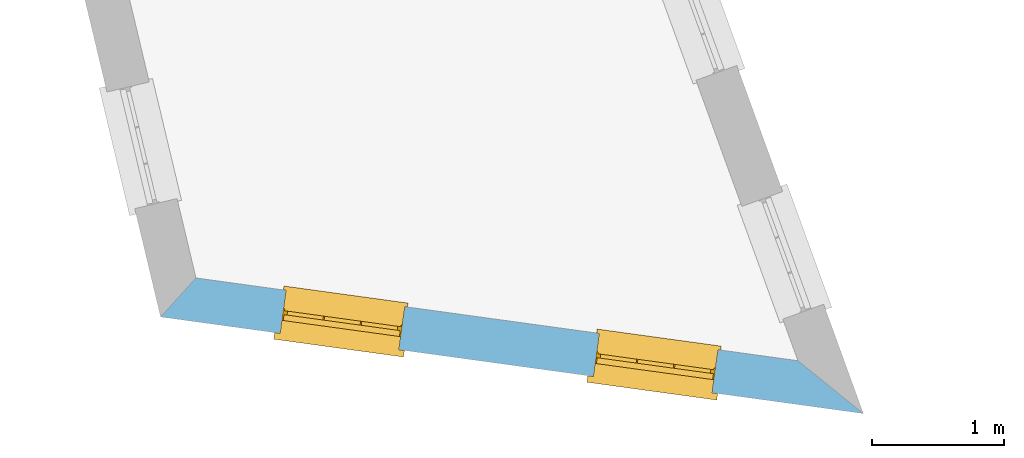
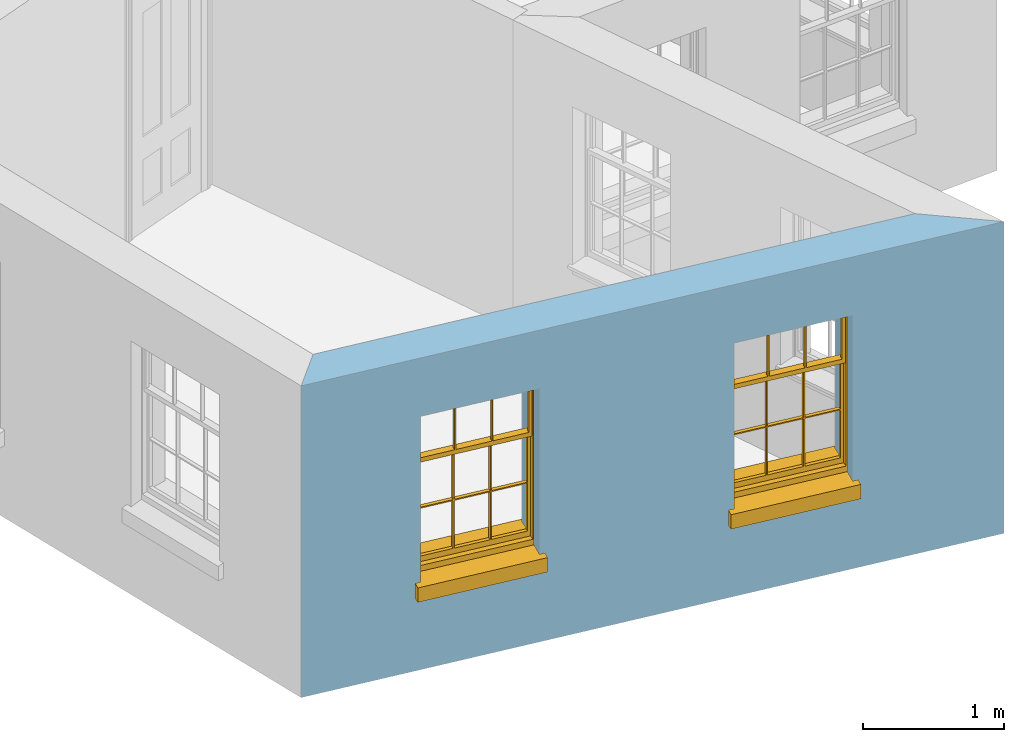
# One storey, part 3 of 12: 2 windows, 2 openings, plus 1 element that does not belong to this part.
"""IFC2X3 building model written with IfcOpenShell, lengths in metres."""

import ifcopenshell
import ifcopenshell.guid

model = None  # the IFC model being written
_history = None  # IfcOwnerHistory: only IFC2X3 demands one
_inside = {}  # id of a spatial element -> (the spatial element, [elements in it])
_under = {}  # id of a project, library or spatial element -> (it, [spatial elements below it])
_declared = {}  # id of a project -> (the project, [libraries it declares])
_typed = {}  # id of a type object -> (the type object, [elements of that type])
_made_of = {}  # id of a material, layer set ... -> (it, [elements and type objects made of it])


def new_model(schema):
    """Start an empty IFC model of exactly this schema.

    Asked for "IFC4X3", IfcOpenShell would pick the latest addendum, in which some entities
    have other attributes; the version numbers below select the first issue.
    IFC2X3 requires an IfcOwnerHistory on every rooted entity: one is made here for all.
    """
    global model, _history
    if schema == "IFC4X3":
        model = ifcopenshell.file(schema_version=(4, 3, 0, 0))
    else:
        model = ifcopenshell.file(schema=schema)
    _inside.clear()
    _under.clear()
    _declared.clear()
    _typed.clear()
    _made_of.clear()
    _history = None
    if model.schema == "IFC2X3":
        org = make("IfcOrganization", Name="unknown")
        user = make(
            "IfcPersonAndOrganization",
            ThePerson=make("IfcPerson", FamilyName="unknown"),
            TheOrganization=org,
        )
        app = make(
            "IfcApplication",
            ApplicationDeveloper=org,
            Version="unknown",
            ApplicationFullName="unknown",
            ApplicationIdentifier="unknown",
        )
        _history = make(
            "IfcOwnerHistory",
            OwningUser=user,
            OwningApplication=app,
            ChangeAction="ADDED",
            CreationDate=0,
        )
    return model


def make(cls, **values):
    """One entity of the class cls with the attributes given. An attribute that is None is left unset."""
    return model.create_entity(
        cls, **{name: value for name, value in values.items() if value is not None}
    )


def rooted(cls, **values):
    """An entity with a GlobalId (a new one), such as an element, a storey or a relation."""
    return make(cls, GlobalId=ifcopenshell.guid.new(), OwnerHistory=_history, **values)


def si_unit(unit_type, name, prefix=None):
    """IfcSIUnit, for example si_unit("LENGTHUNIT", "METRE", prefix="MILLI")."""
    return make("IfcSIUnit", UnitType=unit_type, Prefix=prefix, Name=name)


def assignment(units):
    """IfcUnitAssignment: the units of a project."""
    return None if units is None else make("IfcUnitAssignment", Units=units)


def point(xyz):
    """IfcCartesianPoint."""
    return None if xyz is None else make("IfcCartesianPoint", Coordinates=xyz)


def direction(xyz):
    """IfcDirection."""
    return None if xyz is None else make("IfcDirection", DirectionRatios=xyz)


def frame(location, z_axis=None, x_axis=None):
    """IfcAxis2Placement3D, a coordinate frame: its origin and axes. An axis left out is left unset."""
    return make(
        "IfcAxis2Placement3D",
        Location=point(location),
        Axis=direction(z_axis),
        RefDirection=direction(x_axis),
    )


def origin():
    """The frame at (0, 0, 0) with its axes left unset."""
    return frame((0.0, 0.0, 0.0))


def place(relative_to, where):
    """IfcLocalPlacement: puts the frame where relative to a parent placement (None: the world)."""
    return make(
        "IfcLocalPlacement", PlacementRelTo=relative_to, RelativePlacement=where
    )


def context(
    kind, dimensions, precision=None, world=None, true_north=None, identifier=None
):
    """IfcGeometricRepresentationContext, for example the 3D "Model" context."""
    return make(
        "IfcGeometricRepresentationContext",
        ContextIdentifier=identifier,
        ContextType=kind,
        CoordinateSpaceDimension=dimensions,
        Precision=precision,
        WorldCoordinateSystem=world,
        TrueNorth=true_north,
    )


def subcontext(parent, identifier, kind, view, scale=None):
    """IfcGeometricRepresentationSubContext, for example "Body" below "Model"."""
    return make(
        "IfcGeometricRepresentationSubContext",
        ContextIdentifier=identifier,
        ContextType=kind,
        ParentContext=parent,
        TargetScale=scale,
        TargetView=view,
    )


def project(units=None, contexts=None):
    """IfcProject with its units and contexts."""
    return rooted(
        "IfcProject",
        Name="project",
        RepresentationContexts=contexts,
        UnitsInContext=assignment(units),
    )


def spatial(cls, under=None, at=None, **own):
    """A site, building, storey or space (cls), placed at a placement, below another one or the project."""
    s = rooted(cls, ObjectPlacement=at, **own)
    if under is not None:
        _under.setdefault(under.id(), (under, []))[1].append(s)
    return s


def polyline(points):
    """IfcPolyline through the points."""
    return make("IfcPolyline", Points=[point(p) for p in points])


def outline(outer, holes=None, kind="AREA"):
    """IfcArbitraryClosedProfileDef: a profile drawn as a closed curve; with holes, ...WithVoids."""
    if holes is None:
        return make("IfcArbitraryClosedProfileDef", ProfileType=kind, OuterCurve=outer)
    return make(
        "IfcArbitraryProfileDefWithVoids",
        ProfileType=kind,
        OuterCurve=outer,
        InnerCurves=holes,
    )


def extrude(swept, where, along, depth):
    """IfcExtrudedAreaSolid: the profile swept, set in the frame where, extruded along a direction by depth."""
    return make(
        "IfcExtrudedAreaSolid",
        SweptArea=swept,
        Position=where,
        ExtrudedDirection=direction(along),
        Depth=depth,
    )


def faces_of(points, faces, orient=None, outer=None):
    """IfcFace entities. A face is a list of loops; a loop is a list of indices into points, from 0.

    orient and outer hold one flag for each loop. By default every Orientation is true, the
    first loop of a face is its IfcFaceOuterBound and the others are IfcFaceBound.
    """
    made = []
    for i, loops in enumerate(faces):
        bounds = []
        for j, loop in enumerate(loops):
            is_outer = j == 0 if outer is None else outer[i][j]
            bounds.append(
                make(
                    "IfcFaceOuterBound" if is_outer else "IfcFaceBound",
                    Bound=make("IfcPolyLoop", Polygon=[points[k] for k in loop]),
                    Orientation=True if orient is None else orient[i][j],
                )
            )
        made.append(make("IfcFace", Bounds=bounds))
    return made


def faceted_brep(points, faces, orient=None, outer=None, voids=None):
    """IfcFacetedBrep: a solid bounded by flat faces; with voids (closed shells), ...WithVoids."""
    shared = [point(p) for p in points]
    hull = make("IfcClosedShell", CfsFaces=faces_of(shared, faces, orient, outer))
    if voids is None:
        return make("IfcFacetedBrep", Outer=hull)
    return make(
        "IfcFacetedBrepWithVoids",
        Outer=hull,
        Voids=[
            make(cls, CfsFaces=faces_of(shared, fs, o, b)) for cls, fs, o, b in voids
        ],
    )


def shape(context_of_items, identifier, shape_type, items):
    """IfcShapeRepresentation: the items that make up one representation, for example the "Body"."""
    return make(
        "IfcShapeRepresentation",
        ContextOfItems=context_of_items,
        RepresentationIdentifier=identifier,
        RepresentationType=shape_type,
        Items=items,
    )


def material(Name=None, Category=None):
    """IfcMaterial."""
    return make("IfcMaterial", Name=Name, Category=Category)


def layer(
    of_material, thickness, ventilated=None, Name=None, Category=None, Priority=None
):
    """IfcMaterialLayer: one layer of a wall or slab, of a material (None: an air gap)."""
    return make(
        "IfcMaterialLayer",
        Material=of_material,
        LayerThickness=thickness,
        IsVentilated=ventilated,
        Name=Name,
        Category=Category,
        Priority=Priority,
    )


def layer_set(layers, Name=None):
    """IfcMaterialLayerSet."""
    return make("IfcMaterialLayerSet", MaterialLayers=layers, LayerSetName=Name)


def layer_usage(for_layer_set, set_direction, sense, offset, extent=None):
    """IfcMaterialLayerSetUsage: how a layer set lies in its element."""
    return make(
        "IfcMaterialLayerSetUsage",
        ForLayerSet=for_layer_set,
        LayerSetDirection=set_direction,
        DirectionSense=sense,
        OffsetFromReferenceLine=offset,
        ReferenceExtent=extent,
    )


def made_of(thing, what):
    """Note that an element or type object is made of a material, layer set ...; save() writes the relation."""
    if what is not None:
        _made_of.setdefault(what.id(), (what, []))[1].append(thing)
    return thing


def element(
    cls,
    number,
    at=None,
    inside=None,
    cuts=None,
    type_object=None,
    material=None,
    context=None,
    identifier="Body",
    shape_type=None,
    held_by="IfcProductDefinitionShape",
    body=None,
    shapes=None,
    **own,
):
    """One element of the class cls, such as IfcWall. Its Tag is "e" and its number.

    at: its placement. inside: the storey or other place that contains it. cuts: it is an
    opening in that element (IfcRelVoidsElement). A single representation is given by context,
    identifier, shape_type and body (its items); several are given by shapes. held_by: the class
    of the entity that holds the representations. save() writes the other relations.
    """
    e = rooted(cls, Tag="e%d" % number, ObjectPlacement=at, **own)
    if body is not None:
        shapes = [shape(context, identifier, shape_type, body)]
    if shapes is not None:
        e.Representation = make(held_by, Representations=shapes)
    if inside is not None:
        _inside.setdefault(inside.id(), (inside, []))[1].append(e)
    if cuts is not None:
        rooted(
            "IfcRelVoidsElement", RelatingBuildingElement=cuts, RelatedOpeningElement=e
        )
    if type_object is not None:
        _typed.setdefault(type_object.id(), (type_object, []))[1].append(e)
    return made_of(e, material)


def fill(opening, filler):
    """IfcRelFillsElement: the door or window that sits in an opening."""
    return rooted(
        "IfcRelFillsElement",
        RelatingOpeningElement=opening,
        RelatedBuildingElement=filler,
    )


def aggregate(whole, parts):
    """IfcRelAggregates: a whole, such as a stair, and the parts it consists of."""
    return rooted("IfcRelAggregates", RelatingObject=whole, RelatedObjects=parts)


def save(model, path):
    """Write the relations noted so far, then the file.

    IfcRelAggregates (storeys below a building ...), IfcRelContainedInSpatialStructure (elements
    in a storey), IfcRelDefinesByType, IfcRelAssociatesMaterial and IfcRelDeclares: one each for
    every whole, place, type object, material and project.
    """
    for whole, parts in _under.values():
        aggregate(whole, parts)
    for where, things in _inside.values():
        rooted(
            "IfcRelContainedInSpatialStructure",
            RelatedElements=things,
            RelatingStructure=where,
        )
    for kind, things in _typed.values():
        rooted("IfcRelDefinesByType", RelatedObjects=things, RelatingType=kind)
    for what, things in _made_of.values():
        rooted("IfcRelAssociatesMaterial", RelatedObjects=things, RelatingMaterial=what)
    for by, libraries in _declared.values():
        rooted("IfcRelDeclares", RelatingContext=by, RelatedDefinitions=libraries)
    model.write(path)


model = new_model("IFC2X3")

# Units and contexts
model_context = context("Model", 3, world=origin())
body_context = subcontext(model_context, "Body", "Model", "MODEL_VIEW")
ifc_project = project(units=[si_unit("PLANEANGLEUNIT", "RADIAN"), si_unit("MASSUNIT", "GRAM", prefix="KILO"), si_unit("FORCEUNIT", "NEWTON", prefix="KILO"), si_unit("LENGTHUNIT", "METRE")], contexts=[model_context])

# Site, building, storey
site_placement = place(None, origin())
site = spatial("IfcSite", under=ifc_project, at=site_placement, CompositionType="ELEMENT")
building_placement = place(None, origin())
building = spatial("IfcBuilding", under=site, at=building_placement, Name="Building plot-12", CompositionType="ELEMENT")
storey_placement = place(None, frame((0.0, 0.0, 6.45)))
storey = spatial("IfcBuildingStorey", under=building, at=storey_placement, Name="Floor 1", CompositionType="ELEMENT", Elevation=6.45)

# Wall, openings, windows
ifc_material = material(Name="Masonry")
ifc_layer = layer(ifc_material, 0.33, ventilated=False)
ifc_layer_set = layer_set([ifc_layer], Name="My Wall")
ifc_layer_usage = layer_usage(ifc_layer_set, "AXIS2", "NEGATIVE", 0.08)
wall_placement = place(storey_placement, origin())
wall = element("IfcWallStandardCase", 1, at=wall_placement, inside=storey, material=ifc_layer_usage, Name="exterior", context=body_context, shape_type="SweptSolid", body=[
    extrude(outline(polyline([(55.7885191142734, 31.8858296755126), (55.519891283054, 31.5896553921575), (60.8543376208598, 30.856304618938), (60.357257872223, 31.2577442307242), (55.7885191142734, 31.8858296755126)])), origin(), (0.0, 0.0, 1.0), 2.7),
])
opening_1_placement = place(storey_placement, frame((0.0, 0.0, 0.75)))
opening_1 = element("IfcOpeningElement", 2, at=opening_1_placement, cuts=wall, Name="Opening", ObjectType="Opening", context=body_context, shape_type="SweptSolid", body=[
    extrude(outline(polyline([(56.4271796007389, 31.4649263111671), (57.3287004372119, 31.3409901122377), (57.3736443335269, 31.6679152507388), (56.472123497054, 31.7918514496683), (56.4271796007389, 31.4649263111671)])), origin(), (0.0, 0.0, 1.0), 1.445),
])
opening_2_placement = place(storey_placement, frame((0.0, 0.0, 0.75)))
opening_2 = element("IfcOpeningElement", 3, at=opening_2_placement, cuts=wall, Name="Opening", ObjectType="Opening", context=body_context, shape_type="SweptSolid", body=[
    extrude(outline(polyline([(58.8043620196962, 31.1381241550237), (59.7058828561692, 31.0141879560943), (59.7508267524843, 31.3411130945954), (58.8493059160113, 31.4650492935249), (58.8043620196962, 31.1381241550237)])), origin(), (0.0, 0.0, 1.0), 1.445),
])
window_1_placement = place(storey_placement, frame((56.4612280070382, 31.7125968706377, 0.75), z_axis=(0.0, 0.0, 1.0), x_axis=(0.901520836472962, -0.123936198929485, 0.0)))
window_1 = element("IfcWindow", 4, at=window_1_placement, inside=storey, Name="living outside window", OverallHeight=1.445, OverallWidth=0.91, context=body_context, shape_type="Brep", held_by="IfcProductRepresentation", body=[
    faceted_brep([(0.876875, -0.105, 0.999097), (0.876875, -0.105, 1.411875), (0.9, -0.105, 1.435), (0.033125, -0.105, 1.411875), (0.033125, -0.105, 0.999097), (0.01, -0.105, 1.435), (0.033125, -0.135, 1.411875), (0.01, -0.135, 1.435), (0.033125, -0.135, 0.999097), (0.876875, -0.135, 1.411875), (0.876875, -0.135, 0.999097), (0.9, -0.135, 1.435), (0.033125, -0.105, 0.960972), (0.01, -0.105, 0.960972), (0.033125, -0.105, 0.548195), (0.876875, -0.105, 0.960972), (0.876875, -0.105, 0.548195), (0.9, -0.105, 0.960972), (0.876875, -0.105, 0.538195), (0.876875, -0.105, 0.125417), (0.9, -0.105, 0.077167), (0.033125, -0.105, 0.125417), (0.033125, -0.105, 0.538195), (0.01, -0.105, 0.077167), (0.9, -0.135, 0.960972), (0.01, -0.135, 0.960972), (-0.0425, -0.25, 0.01), (-0.0425, -0.3, 0.001667), (0.0, -0.25, 0.01), (0.9525, -0.25, 0.01), (0.91, -0.25, 0.01), (0.9525, -0.3, 0.001667), (-0.02, 0.08, 0.077167), (0.0, 0.08, 0.077167), (-0.02, 0.11, 0.077167), (0.0, -0.06, 0.077167), (0.01, -0.06, 0.077167), (0.91, -0.06, 0.077167), (0.91, 0.08, 0.077167), (0.9, -0.06, 0.077167), (0.93, 0.08, 0.077167), (0.93, 0.11, 0.077167), (0.01, -0.105, 0.999097), (0.01, -0.075, 0.999097), (0.9, -0.105, 0.999097), (0.9, -0.075, 0.999097), (0.876875, -0.075, 0.125417), (0.876875, -0.075, 0.538195), (0.9, -0.075, 0.077167), (0.876875, -0.075, 0.548195), (0.876875, -0.075, 0.960972), (0.033125, -0.075, 0.125417), (0.01, -0.075, 0.077167), (0.033125, -0.075, 0.538195), (0.033125, -0.075, 0.960972), (0.033125, -0.075, 0.548195), (-0.02, 0.08, 0.052167), (-0.02, 0.11, 0.052167), (0.93, 0.11, 0.052167), (0.93, 0.08, 0.052167), (0.91, 0.08, 0.052167), (0.0, 0.08, 0.052167), (0.91, -0.15, 0.026667), (0.0, -0.15, 0.026667), (-0.0425, -0.3, -0.123333), (0.9525, -0.3, -0.123333), (-0.0425, -0.25, -0.123333), (0.9525, -0.25, -0.123333), (0.01, -0.06, 1.435), (0.9, -0.06, 1.435), (0.0, -0.06, 1.445), (0.91, -0.06, 1.445), (0.01, -0.15, 0.077167), (0.9, -0.15, 0.077167), (0.592292, -0.105, 0.125417), (0.592292, -0.075, 0.125417), (0.317708, -0.075, 0.125417), (0.317708, -0.105, 0.125417), (0.592292, -0.105, 0.548195), (0.317708, -0.105, 0.548195), (0.317708, -0.105, 0.538195), (0.592292, -0.105, 0.538195), (0.592292, -0.075, 0.548195), (0.317708, -0.075, 0.548195), (0.602292, -0.075, 0.548195), (0.602292, -0.105, 0.548195), (0.317708, -0.075, 0.538195), (0.307708, -0.075, 0.125417), (0.307708, -0.075, 0.538195), (0.602292, -0.075, 0.538195), (0.602292, -0.075, 0.125417), (0.592292, -0.075, 0.538195), (0.307708, -0.075, 0.548195), (0.317708, -0.075, 0.960972), (0.307708, -0.075, 0.960972), (0.602292, -0.075, 0.960972), (0.592292, -0.075, 0.960972), (0.307708, -0.105, 0.538195), (0.307708, -0.105, 0.125417), (0.307708, -0.105, 0.548195), (0.307708, -0.105, 0.960972), (0.592292, -0.105, 0.960972), (0.317708, -0.105, 0.960972), (0.602292, -0.105, 0.960972), (0.602292, -0.105, 0.538195), (0.602292, -0.105, 0.125417), (0.317708, -0.135, 1.411875), (0.307708, -0.135, 1.411875), (0.307708, -0.135, 0.999097), (0.317708, -0.135, 0.999097), (0.602292, -0.135, 1.411875), (0.592292, -0.135, 1.411875), (0.592292, -0.135, 0.999097), (0.602292, -0.135, 0.999097), (0.317708, -0.105, 0.999097), (0.307708, -0.105, 0.999097), (0.307708, -0.105, 1.411875), (0.317708, -0.105, 1.411875), (0.602292, -0.105, 0.999097), (0.592292, -0.105, 0.999097), (0.592292, -0.105, 1.411875), (0.602292, -0.105, 1.411875), (0.91, -0.15, 1.445), (0.9, -0.15, 1.435), (0.01, -0.15, 1.435), (0.0, -0.15, 1.445), (0.91, -0.25, 0.0), (0.0, -0.25, 0.0), (0.91, 0.08, 0.0), (0.0, 0.08, 0.0)], [[[0, 1, 2]], [[3, 4, 5]], [[6, 7, 8]], [[9, 10, 11]], [[12, 13, 14]], [[15, 16, 17]], [[18, 19, 20]], [[21, 22, 23]], [[24, 15, 17]], [[13, 12, 25]], [[26, 27, 28]], [[29, 30, 31]], [[32, 33, 34]], [[35, 36, 33]], [[37, 38, 39]], [[40, 41, 38]], [[42, 4, 43]], [[44, 45, 0]], [[46, 47, 48]], [[49, 50, 45]], [[51, 52, 53]], [[54, 55, 43]], [[38, 33, 36, 39]], [[41, 34, 33, 38]], [[56, 32, 34, 57]], [[57, 34, 41, 58]], [[58, 41, 40, 59]], [[57, 58, 60, 61]], [[52, 48, 39, 36]], [[62, 63, 28, 30]], [[27, 31, 30, 28]], [[27, 64, 65, 31]], [[66, 67, 65, 64]], [[2, 5, 68, 69]], [[68, 70, 71, 69]], [[20, 23, 72, 73]], [[73, 72, 63, 62]], [[74, 75, 76, 77]], [[78, 79, 80, 81]], [[78, 82, 83, 79]], [[16, 49, 84, 85]], [[86, 76, 87, 88]], [[89, 90, 75, 91]], [[92, 88, 53, 55]], [[82, 91, 86, 83]], [[93, 83, 92, 94]], [[95, 84, 82, 96]], [[89, 84, 49, 47]], [[97, 88, 87, 98]], [[22, 53, 88, 97]], [[81, 91, 75, 74]], [[80, 86, 91, 81]], [[77, 76, 86, 80]], [[99, 92, 55, 14]], [[100, 94, 92, 99]], [[101, 96, 82, 78]], [[79, 83, 93, 102]], [[85, 84, 95, 103]], [[104, 89, 47, 18]], [[105, 90, 89, 104]], [[104, 18, 16, 85]], [[80, 97, 98, 77]], [[104, 81, 74, 105]], [[103, 101, 78, 85]], [[99, 14, 22, 97]], [[102, 100, 99, 79]], [[106, 107, 108, 109]], [[110, 111, 112, 113]], [[114, 115, 116, 117]], [[118, 119, 120, 121]], [[107, 116, 115, 108]], [[111, 120, 119, 112]], [[109, 114, 117, 106]], [[113, 118, 121, 110]], [[85, 78, 81, 104]], [[84, 89, 91, 82]], [[83, 86, 88, 92]], [[79, 99, 97, 80]], [[109, 112, 119, 114]], [[102, 93, 96, 101]], [[106, 117, 120, 111]], [[98, 87, 51, 21]], [[6, 3, 116, 107]], [[110, 121, 1, 9]], [[19, 46, 90, 105]], [[26, 66, 64, 27]], [[29, 31, 65, 67]], [[25, 24, 112, 109]], [[11, 7, 106, 111]], [[75, 48, 52, 76]], [[43, 45, 96, 93]], [[45, 43, 114, 119]], [[5, 2, 120, 117]], [[24, 25, 102, 101]], [[42, 5, 4]], [[2, 44, 0]], [[49, 45, 48, 47]], [[52, 43, 55, 53]], [[14, 13, 23, 22]], [[20, 17, 16, 18]], [[24, 11, 10]], [[25, 8, 7]], [[8, 4, 3, 6]], [[9, 1, 0, 10]], [[15, 50, 49, 16]], [[18, 47, 46, 19]], [[21, 51, 53, 22]], [[14, 55, 54, 12]], [[44, 2, 69, 45]], [[68, 5, 42, 43]], [[36, 35, 70, 68]], [[39, 69, 71, 37]], [[62, 122, 123, 73]], [[63, 72, 124, 125]], [[8, 108, 115, 4]], [[113, 10, 0, 118]], [[94, 100, 12, 54]], [[17, 20, 73, 24]], [[72, 23, 13, 25]], [[52, 36, 68, 43]], [[69, 39, 48, 45]], [[11, 24, 73, 123]], [[7, 124, 72, 25]], [[23, 77, 98]], [[98, 21, 23]], [[105, 74, 20]], [[20, 19, 105]], [[20, 74, 77, 23]], [[113, 112, 24]], [[24, 10, 113]], [[25, 109, 108]], [[108, 8, 25]], [[110, 9, 11]], [[11, 111, 110]], [[7, 6, 107]], [[107, 106, 7]], [[5, 117, 116]], [[116, 3, 5]], [[121, 120, 2]], [[2, 1, 121]], [[11, 123, 124, 7]], [[122, 125, 124, 123]], [[43, 93, 94]], [[94, 54, 43]], [[96, 45, 95]], [[50, 95, 45]], [[15, 103, 95, 50]], [[48, 75, 90]], [[90, 46, 48]], [[87, 76, 52]], [[52, 51, 87]], [[103, 15, 24]], [[24, 101, 103]], [[100, 102, 25]], [[25, 12, 100]], [[115, 114, 43]], [[43, 4, 115]], [[118, 0, 45]], [[45, 119, 118]], [[71, 70, 125, 122]], [[70, 35, 63, 125]], [[122, 62, 37, 71]], [[126, 67, 66, 127]], [[60, 58, 59]], [[38, 60, 59, 40]], [[61, 56, 57]], [[32, 56, 61, 33]], [[61, 60, 128, 129]], [[62, 60, 38, 37]], [[126, 128, 60, 62]], [[33, 61, 63, 35]], [[61, 129, 127, 63]], [[128, 126, 127, 129]], [[28, 127, 66, 26]], [[63, 127, 28]], [[29, 67, 126, 30]], [[30, 126, 62]]]),
])
fill(opening_1, window_1)
window_2_placement = place(storey_placement, frame((58.8384104259955, 31.3857947144943, 0.75), z_axis=(0.0, 0.0, 1.0), x_axis=(0.901520836472962, -0.123936198929485, 0.0)))
window_2 = element("IfcWindow", 5, at=window_2_placement, inside=storey, Name="living outside window", OverallHeight=1.445, OverallWidth=0.91, context=body_context, shape_type="Brep", held_by="IfcProductRepresentation", body=[
    faceted_brep([(0.876875, -0.105, 0.999097), (0.876875, -0.105, 1.411875), (0.9, -0.105, 1.435), (0.033125, -0.105, 1.411875), (0.033125, -0.105, 0.999097), (0.01, -0.105, 1.435), (0.033125, -0.135, 1.411875), (0.01, -0.135, 1.435), (0.033125, -0.135, 0.999097), (0.876875, -0.135, 1.411875), (0.876875, -0.135, 0.999097), (0.9, -0.135, 1.435), (0.033125, -0.105, 0.960972), (0.01, -0.105, 0.960972), (0.033125, -0.105, 0.548195), (0.876875, -0.105, 0.960972), (0.876875, -0.105, 0.548195), (0.9, -0.105, 0.960972), (0.876875, -0.105, 0.538195), (0.876875, -0.105, 0.125417), (0.9, -0.105, 0.077167), (0.033125, -0.105, 0.125417), (0.033125, -0.105, 0.538195), (0.01, -0.105, 0.077167), (0.9, -0.135, 0.960972), (0.01, -0.135, 0.960972), (-0.0425, -0.25, 0.01), (-0.0425, -0.3, 0.001667), (0.0, -0.25, 0.01), (0.9525, -0.25, 0.01), (0.91, -0.25, 0.01), (0.9525, -0.3, 0.001667), (-0.02, 0.08, 0.077167), (0.0, 0.08, 0.077167), (-0.02, 0.11, 0.077167), (0.0, -0.06, 0.077167), (0.01, -0.06, 0.077167), (0.91, -0.06, 0.077167), (0.91, 0.08, 0.077167), (0.9, -0.06, 0.077167), (0.93, 0.08, 0.077167), (0.93, 0.11, 0.077167), (0.01, -0.105, 0.999097), (0.01, -0.075, 0.999097), (0.9, -0.105, 0.999097), (0.9, -0.075, 0.999097), (0.876875, -0.075, 0.125417), (0.876875, -0.075, 0.538195), (0.9, -0.075, 0.077167), (0.876875, -0.075, 0.548195), (0.876875, -0.075, 0.960972), (0.033125, -0.075, 0.125417), (0.01, -0.075, 0.077167), (0.033125, -0.075, 0.538195), (0.033125, -0.075, 0.960972), (0.033125, -0.075, 0.548195), (-0.02, 0.08, 0.052167), (-0.02, 0.11, 0.052167), (0.93, 0.11, 0.052167), (0.93, 0.08, 0.052167), (0.91, 0.08, 0.052167), (0.0, 0.08, 0.052167), (0.91, -0.15, 0.026667), (0.0, -0.15, 0.026667), (-0.0425, -0.3, -0.123333), (0.9525, -0.3, -0.123333), (-0.0425, -0.25, -0.123333), (0.9525, -0.25, -0.123333), (0.01, -0.06, 1.435), (0.9, -0.06, 1.435), (0.0, -0.06, 1.445), (0.91, -0.06, 1.445), (0.01, -0.15, 0.077167), (0.9, -0.15, 0.077167), (0.592292, -0.105, 0.125417), (0.592292, -0.075, 0.125417), (0.317708, -0.075, 0.125417), (0.317708, -0.105, 0.125417), (0.592292, -0.105, 0.548195), (0.317708, -0.105, 0.548195), (0.317708, -0.105, 0.538195), (0.592292, -0.105, 0.538195), (0.592292, -0.075, 0.548195), (0.317708, -0.075, 0.548195), (0.602292, -0.075, 0.548195), (0.602292, -0.105, 0.548195), (0.317708, -0.075, 0.538195), (0.307708, -0.075, 0.125417), (0.307708, -0.075, 0.538195), (0.602292, -0.075, 0.538195), (0.602292, -0.075, 0.125417), (0.592292, -0.075, 0.538195), (0.307708, -0.075, 0.548195), (0.317708, -0.075, 0.960972), (0.307708, -0.075, 0.960972), (0.602292, -0.075, 0.960972), (0.592292, -0.075, 0.960972), (0.307708, -0.105, 0.538195), (0.307708, -0.105, 0.125417), (0.307708, -0.105, 0.548195), (0.307708, -0.105, 0.960972), (0.592292, -0.105, 0.960972), (0.317708, -0.105, 0.960972), (0.602292, -0.105, 0.960972), (0.602292, -0.105, 0.538195), (0.602292, -0.105, 0.125417), (0.317708, -0.135, 1.411875), (0.307708, -0.135, 1.411875), (0.307708, -0.135, 0.999097), (0.317708, -0.135, 0.999097), (0.602292, -0.135, 1.411875), (0.592292, -0.135, 1.411875), (0.592292, -0.135, 0.999097), (0.602292, -0.135, 0.999097), (0.317708, -0.105, 0.999097), (0.307708, -0.105, 0.999097), (0.307708, -0.105, 1.411875), (0.317708, -0.105, 1.411875), (0.602292, -0.105, 0.999097), (0.592292, -0.105, 0.999097), (0.592292, -0.105, 1.411875), (0.602292, -0.105, 1.411875), (0.91, -0.15, 1.445), (0.9, -0.15, 1.435), (0.01, -0.15, 1.435), (0.0, -0.15, 1.445), (0.91, -0.25, 0.0), (0.0, -0.25, 0.0), (0.91, 0.08, 0.0), (0.0, 0.08, 0.0)], [[[0, 1, 2]], [[3, 4, 5]], [[6, 7, 8]], [[9, 10, 11]], [[12, 13, 14]], [[15, 16, 17]], [[18, 19, 20]], [[21, 22, 23]], [[24, 15, 17]], [[13, 12, 25]], [[26, 27, 28]], [[29, 30, 31]], [[32, 33, 34]], [[35, 36, 33]], [[37, 38, 39]], [[40, 41, 38]], [[42, 4, 43]], [[44, 45, 0]], [[46, 47, 48]], [[49, 50, 45]], [[51, 52, 53]], [[54, 55, 43]], [[38, 33, 36, 39]], [[41, 34, 33, 38]], [[56, 32, 34, 57]], [[57, 34, 41, 58]], [[58, 41, 40, 59]], [[57, 58, 60, 61]], [[52, 48, 39, 36]], [[62, 63, 28, 30]], [[27, 31, 30, 28]], [[27, 64, 65, 31]], [[66, 67, 65, 64]], [[2, 5, 68, 69]], [[68, 70, 71, 69]], [[20, 23, 72, 73]], [[73, 72, 63, 62]], [[74, 75, 76, 77]], [[78, 79, 80, 81]], [[78, 82, 83, 79]], [[16, 49, 84, 85]], [[86, 76, 87, 88]], [[89, 90, 75, 91]], [[92, 88, 53, 55]], [[82, 91, 86, 83]], [[93, 83, 92, 94]], [[95, 84, 82, 96]], [[89, 84, 49, 47]], [[97, 88, 87, 98]], [[22, 53, 88, 97]], [[81, 91, 75, 74]], [[80, 86, 91, 81]], [[77, 76, 86, 80]], [[99, 92, 55, 14]], [[100, 94, 92, 99]], [[101, 96, 82, 78]], [[79, 83, 93, 102]], [[85, 84, 95, 103]], [[104, 89, 47, 18]], [[105, 90, 89, 104]], [[104, 18, 16, 85]], [[80, 97, 98, 77]], [[104, 81, 74, 105]], [[103, 101, 78, 85]], [[99, 14, 22, 97]], [[102, 100, 99, 79]], [[106, 107, 108, 109]], [[110, 111, 112, 113]], [[114, 115, 116, 117]], [[118, 119, 120, 121]], [[107, 116, 115, 108]], [[111, 120, 119, 112]], [[109, 114, 117, 106]], [[113, 118, 121, 110]], [[85, 78, 81, 104]], [[84, 89, 91, 82]], [[83, 86, 88, 92]], [[79, 99, 97, 80]], [[109, 112, 119, 114]], [[102, 93, 96, 101]], [[106, 117, 120, 111]], [[98, 87, 51, 21]], [[6, 3, 116, 107]], [[110, 121, 1, 9]], [[19, 46, 90, 105]], [[26, 66, 64, 27]], [[29, 31, 65, 67]], [[25, 24, 112, 109]], [[11, 7, 106, 111]], [[75, 48, 52, 76]], [[43, 45, 96, 93]], [[45, 43, 114, 119]], [[5, 2, 120, 117]], [[24, 25, 102, 101]], [[42, 5, 4]], [[2, 44, 0]], [[49, 45, 48, 47]], [[52, 43, 55, 53]], [[14, 13, 23, 22]], [[20, 17, 16, 18]], [[24, 11, 10]], [[25, 8, 7]], [[8, 4, 3, 6]], [[9, 1, 0, 10]], [[15, 50, 49, 16]], [[18, 47, 46, 19]], [[21, 51, 53, 22]], [[14, 55, 54, 12]], [[44, 2, 69, 45]], [[68, 5, 42, 43]], [[36, 35, 70, 68]], [[39, 69, 71, 37]], [[62, 122, 123, 73]], [[63, 72, 124, 125]], [[8, 108, 115, 4]], [[113, 10, 0, 118]], [[94, 100, 12, 54]], [[17, 20, 73, 24]], [[72, 23, 13, 25]], [[52, 36, 68, 43]], [[69, 39, 48, 45]], [[11, 24, 73, 123]], [[7, 124, 72, 25]], [[23, 77, 98]], [[98, 21, 23]], [[105, 74, 20]], [[20, 19, 105]], [[20, 74, 77, 23]], [[113, 112, 24]], [[24, 10, 113]], [[25, 109, 108]], [[108, 8, 25]], [[110, 9, 11]], [[11, 111, 110]], [[7, 6, 107]], [[107, 106, 7]], [[5, 117, 116]], [[116, 3, 5]], [[121, 120, 2]], [[2, 1, 121]], [[11, 123, 124, 7]], [[122, 125, 124, 123]], [[43, 93, 94]], [[94, 54, 43]], [[96, 45, 95]], [[50, 95, 45]], [[15, 103, 95, 50]], [[48, 75, 90]], [[90, 46, 48]], [[87, 76, 52]], [[52, 51, 87]], [[103, 15, 24]], [[24, 101, 103]], [[100, 102, 25]], [[25, 12, 100]], [[115, 114, 43]], [[43, 4, 115]], [[118, 0, 45]], [[45, 119, 118]], [[71, 70, 125, 122]], [[70, 35, 63, 125]], [[122, 62, 37, 71]], [[126, 67, 66, 127]], [[60, 58, 59]], [[38, 60, 59, 40]], [[61, 56, 57]], [[32, 56, 61, 33]], [[61, 60, 128, 129]], [[62, 60, 38, 37]], [[126, 128, 60, 62]], [[33, 61, 63, 35]], [[61, 129, 127, 63]], [[128, 126, 127, 129]], [[28, 127, 66, 26]], [[63, 127, 28]], [[29, 67, 126, 30]], [[30, 126, 62]]]),
])
fill(opening_2, window_2)

save(model, "model.ifc")
